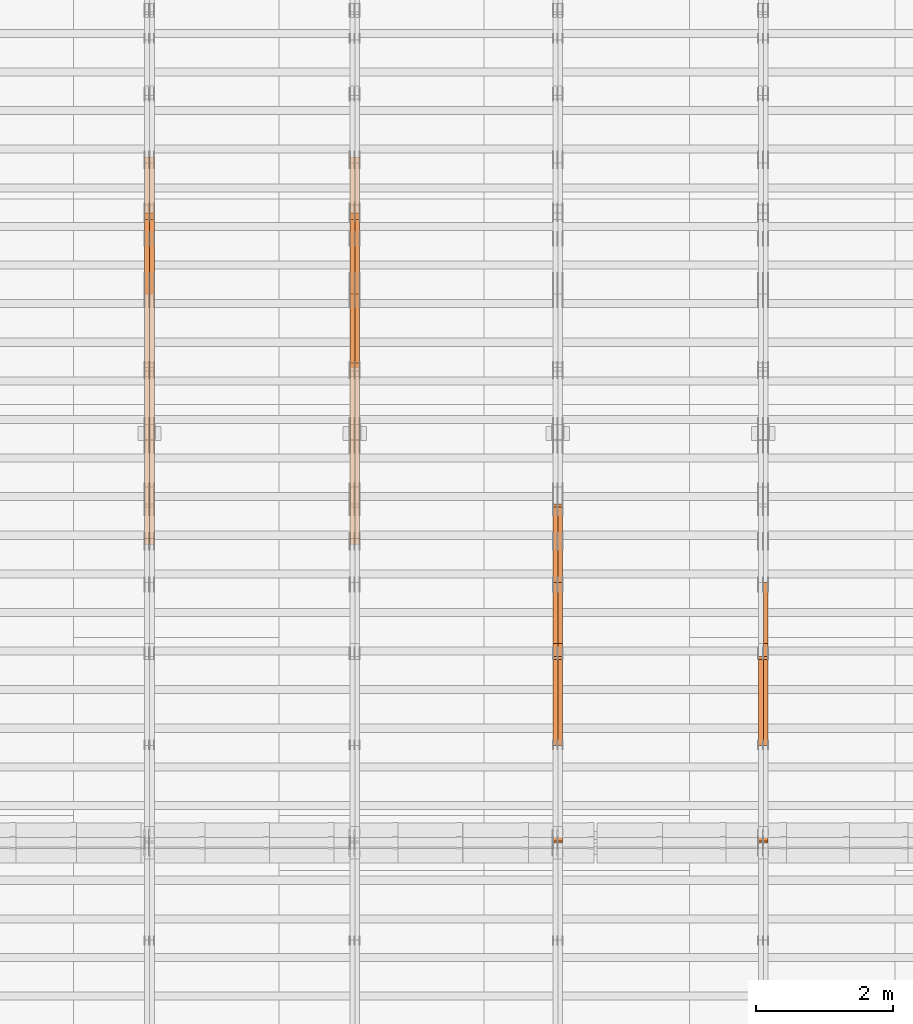
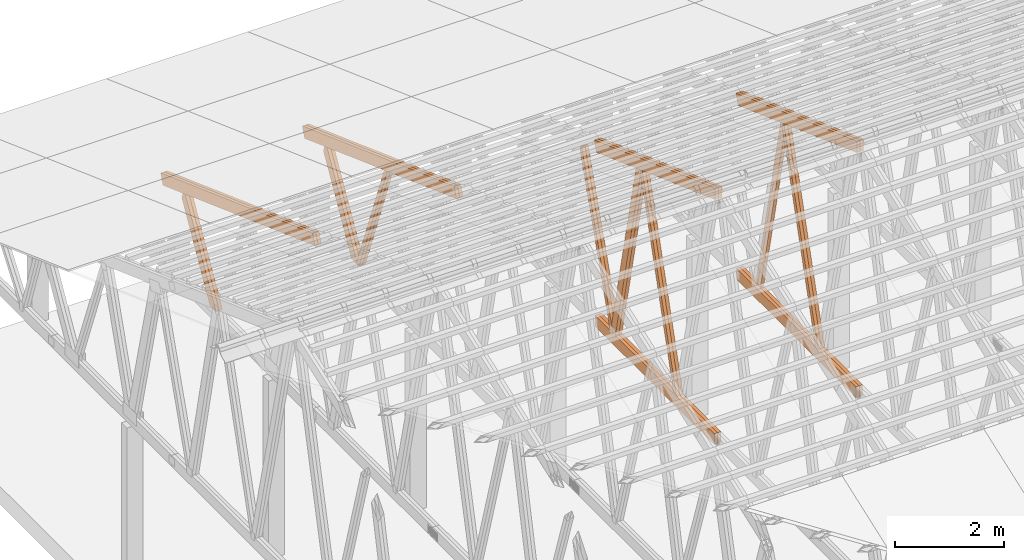
# One storey, part 33 of 189: 27 proxies.
"""IFC2X3 building model written with IfcOpenShell, lengths in millimetres."""

from ifc_helpers import new_model, entity, si_unit, converted_unit, derived_unit, direction, frame, origin, origin_2d_with_axis, place, context, subcontext, project, spatial, polyline, rectangle, outline, extrude, source, transform, mapped, material, type_object, type_shapes, element, save


model = new_model("IFC2X3")

# Units and contexts
model_context = context("Model", 3, precision=0.01, world=origin(), true_north=direction((6.12303176911189e-17, 1.0)))
body_context = subcontext(model_context, "Body", "Model", "MODEL_VIEW")
ifc_project = project(units=[si_unit("LENGTHUNIT", "METRE", prefix="MILLI"), si_unit("AREAUNIT", "SQUARE_METRE"), si_unit("VOLUMEUNIT", "CUBIC_METRE"), converted_unit("PLANEANGLEUNIT", "DEGREE", entity("IfcRatioMeasure", 0.0174532925199433), si_unit("PLANEANGLEUNIT", "RADIAN"), dimensions=[0, 0, 0, 0, 0, 0, 0]), si_unit("MASSUNIT", "GRAM", prefix="KILO"), derived_unit("MASSDENSITYUNIT", [(si_unit("MASSUNIT", "GRAM", prefix="KILO"), 1), (si_unit("LENGTHUNIT", "METRE"), -3)]), si_unit("TIMEUNIT", "SECOND"), si_unit("FREQUENCYUNIT", "HERTZ"), si_unit("THERMODYNAMICTEMPERATUREUNIT", "DEGREE_CELSIUS"), derived_unit("THERMALTRANSMITTANCEUNIT", [(si_unit("MASSUNIT", "GRAM", prefix="KILO"), 1), (si_unit("THERMODYNAMICTEMPERATUREUNIT", "KELVIN"), -1), (si_unit("TIMEUNIT", "SECOND"), -3)]), derived_unit("VOLUMETRICFLOWRATEUNIT", [(si_unit("LENGTHUNIT", "METRE"), 3), (si_unit("TIMEUNIT", "SECOND"), -1)]), si_unit("ELECTRICCURRENTUNIT", "AMPERE"), si_unit("ELECTRICVOLTAGEUNIT", "VOLT"), si_unit("POWERUNIT", "WATT"), si_unit("FORCEUNIT", "NEWTON"), si_unit("ILLUMINANCEUNIT", "LUX"), si_unit("LUMINOUSFLUXUNIT", "LUMEN"), si_unit("LUMINOUSINTENSITYUNIT", "CANDELA"), derived_unit("USERDEFINED", [(si_unit("MASSUNIT", "GRAM", prefix="KILO"), -1), (si_unit("LENGTHUNIT", "METRE"), -2), (si_unit("TIMEUNIT", "SECOND"), 3), (si_unit("LUMINOUSFLUXUNIT", "LUMEN"), 1)]), derived_unit("LINEARVELOCITYUNIT", [(si_unit("LENGTHUNIT", "METRE"), 1), (si_unit("TIMEUNIT", "SECOND"), -1)]), si_unit("PRESSUREUNIT", "PASCAL"), derived_unit("USERDEFINED", [(si_unit("LENGTHUNIT", "METRE"), -2), (si_unit("MASSUNIT", "GRAM", prefix="KILO"), 1), (si_unit("TIMEUNIT", "SECOND"), -2)])], contexts=[model_context])

# Site, building, storey
site_placement = place(None, origin())
site = spatial("IfcSite", under=ifc_project, at=site_placement, CompositionType="ELEMENT")
building_placement = place(site_placement, origin())
building = spatial("IfcBuilding", under=site, at=building_placement, CompositionType="ELEMENT")
storey_placement = place(building_placement, origin())
storey = spatial("IfcBuildingStorey", under=building, at=storey_placement, Name="Default", CompositionType="ELEMENT", Elevation=0.0)

# Proxies
ifc_material_1 = material(Name="IfcSurfaceStyle #68238")
building_element_proxy_type_1 = type_object("IfcBuildingElementProxyType", Name="T1-W6 68236", PredefinedType="NOTDEFINED", material=ifc_material_1)
shared_shape_1 = source(origin(), body_context, "Body", "SweptSolid", [
    extrude(outline(polyline([(-2668.68989660745, -47.5002238228721), (1800.72567700045, -47.5002238228721), (1797.68490303083, 0.000158637170537834), (1711.12272493628, 47.5001445042868), (-2640.84340836012, 47.5001445042868), (-2668.68989660745, -47.5002238228721)])), frame((1800.7257704503, 47.5001445042868, 0.0), z_axis=(0.0, 0.0, 1.0), x_axis=(-1.0, 0.0, 0.0)), (0.0, 0.0, 1.0), 69.9999999999997),
])
type_shapes(building_element_proxy_type_1, [shared_shape_1])
proxy_1_placement = place(building_placement, frame((12300.0, 17516.8749791841, 4507.23620831254), z_axis=(-1.0, 0.0, 0.0), x_axis=(0.0, -0.281285983104611, -0.959623986626466)))
element("IfcBuildingElementProxy", 1, at=proxy_1_placement, inside=storey, type_object=building_element_proxy_type_1, material=ifc_material_1, Name="T1-W6", context=body_context, shape_type="MappedRepresentation", body=[
    mapped(shared_shape_1, transform((0.0, 0.0, 0.0), scale=1.0)),
])
ifc_material_2 = material(Name="IfcSurfaceStyle #68172")
building_element_proxy_type_2 = type_object("IfcBuildingElementProxyType", Name="T1-W6 68170", PredefinedType="NOTDEFINED", material=ifc_material_2)
shared_shape_2 = source(origin(), body_context, "Body", "SweptSolid", [
    extrude(outline(polyline([(-2668.68989660745, -47.5002238228721), (1800.72567700045, -47.5002238228721), (1797.68490303083, 0.000158637170537834), (1711.12272493628, 47.5001445042868), (-2640.84340836012, 47.5001445042868), (-2668.68989660745, -47.5002238228721)])), frame((1800.7257704503, 47.5001445042868, 0.0), z_axis=(0.0, 0.0, 1.0), x_axis=(-1.0, 0.0, 0.0)), (0.0, 0.0, 1.0), 69.9999999999997),
])
type_shapes(building_element_proxy_type_2, [shared_shape_2])
proxy_2_placement = place(building_placement, frame((12230.0, 17516.8749791841, 4507.23620831254), z_axis=(-1.0, 0.0, 0.0), x_axis=(0.0, -0.281285983104611, -0.959623986626466)))
element("IfcBuildingElementProxy", 2, at=proxy_2_placement, inside=storey, type_object=building_element_proxy_type_2, material=ifc_material_2, Name="T1-W6", context=body_context, shape_type="MappedRepresentation", body=[
    mapped(shared_shape_2, transform((0.0, 0.0, 0.0), scale=1.0)),
])
ifc_material_3 = material(Name="IfcSurfaceStyle #67974")
building_element_proxy_type_3 = type_object("IfcBuildingElementProxyType", Name="T1-W3 67972", PredefinedType="NOTDEFINED", material=ifc_material_3)
shared_shape_3 = source(origin(), body_context, "Body", "SweptSolid", [
    extrude(outline(polyline([(-2517.58938959787, -85.0001104675026), (1625.445846867, -85.0001104675027), (1768.20563426494, 0.000209440697654673), (1749.48871563991, 85.0000057471538), (-2625.55080717397, 85.0000057471538), (-2517.58938959787, -85.0001104675026)])), frame((1768.2056683344, 85.0000547211315, 0.0), z_axis=(0.0, 0.0, 1.0), x_axis=(-1.0, 0.0, 0.0)), (0.0, 0.0, 1.0), 69.9999999999997),
])
type_shapes(building_element_proxy_type_3, [shared_shape_3])
proxy_3_placement = place(building_placement, frame((12300.0, 18415.3042863408, 226.720947016584), z_axis=(-1.0, 0.0, 0.0), x_axis=(0.0, -0.215047682154604, 0.976603550269982)))
element("IfcBuildingElementProxy", 3, at=proxy_3_placement, inside=storey, type_object=building_element_proxy_type_3, material=ifc_material_3, Name="T1-W3", context=body_context, shape_type="MappedRepresentation", body=[
    mapped(shared_shape_3, transform((0.0, 0.0, 0.0), scale=1.0)),
])
ifc_material_4 = material(Name="IfcSurfaceStyle #64464")
building_element_proxy_type_4 = type_object("IfcBuildingElementProxyType", Name="T1-B5 64462", PredefinedType="NOTDEFINED", material=ifc_material_4)
shared_shape_4 = source(origin(), body_context, "Body", "SweptSolid", [
    extrude(rectangle(XDim=4381.5, YDim=245.000000000001, at=origin_2d_with_axis()), frame((2190.75, 122.5, 0.0), z_axis=(0.0, 0.0, 1.0), x_axis=(-1.0, 0.0, 0.0)), (0.0, 0.0, 1.0), 69.9999999999997),
])
type_shapes(building_element_proxy_type_4, [shared_shape_4])
proxy_4_placement = place(building_placement, frame((12300.0, 14780.2587890625, 245.0), z_axis=(-1.0, 0.0, 0.0), x_axis=(0.0, 1.0, 0.0)))
element("IfcBuildingElementProxy", 4, at=proxy_4_placement, inside=storey, type_object=building_element_proxy_type_4, material=ifc_material_4, Name="T1-B5", context=body_context, shape_type="MappedRepresentation", body=[
    mapped(shared_shape_4, transform((0.0, 0.0, 0.0), scale=1.0)),
])
ifc_material_5 = material(Name="IfcSurfaceStyle #64407")
building_element_proxy_type_5 = type_object("IfcBuildingElementProxyType", Name="T1-B5 64405", PredefinedType="NOTDEFINED", material=ifc_material_5)
shared_shape_5 = source(origin(), body_context, "Body", "SweptSolid", [
    extrude(rectangle(XDim=4381.5, YDim=245.000000000001, at=origin_2d_with_axis()), frame((2190.75, 122.5, 0.0), z_axis=(0.0, 0.0, 1.0), x_axis=(-1.0, 0.0, 0.0)), (0.0, 0.0, 1.0), 69.9999999999997),
])
type_shapes(building_element_proxy_type_5, [shared_shape_5])
proxy_5_placement = place(building_placement, frame((12230.0, 14780.2587890625, 245.0), z_axis=(-1.0, 0.0, 0.0), x_axis=(0.0, 1.0, 0.0)))
element("IfcBuildingElementProxy", 5, at=proxy_5_placement, inside=storey, type_object=building_element_proxy_type_5, material=ifc_material_5, Name="T1-B5", context=body_context, shape_type="MappedRepresentation", body=[
    mapped(shared_shape_5, transform((0.0, 0.0, 0.0), scale=1.0)),
])
ifc_material_6 = material(Name="IfcSurfaceStyle #63648")
building_element_proxy_type_6 = type_object("IfcBuildingElementProxyType", Name="T1-T3 63646", PredefinedType="NOTDEFINED", material=ifc_material_6)
shared_shape_6 = source(origin(), body_context, "Body", "SweptSolid", [
    extrude(outline(polyline([(-2386.23525922045, -122.500022994835), (2341.64890001386, -122.500022994835), (2341.64888416412, 122.500022994835), (-2297.06252495753, 122.500022994835), (-2386.23525922045, -122.500022994835)])), frame((2341.64890001386, 122.500051926629, 0.0), z_axis=(0.0, 0.0, 1.0), x_axis=(-1.0, 0.0, 0.0)), (0.0, 0.0, 1.0), 69.9999999999997),
])
type_shapes(building_element_proxy_type_6, [shared_shape_6])
proxy_6_placement = place(building_placement, frame((12300.0, 19108.9628956236, 3921.30465489208), z_axis=(-1.0, 0.0, 0.0), x_axis=(0.0, -0.939692620785908, 0.342020143325669)))
element("IfcBuildingElementProxy", 6, at=proxy_6_placement, inside=storey, type_object=building_element_proxy_type_6, material=ifc_material_6, Name="T1-T3", context=body_context, shape_type="MappedRepresentation", body=[
    mapped(shared_shape_6, transform((0.0, 0.0, 0.0), scale=1.0)),
])
ifc_material_7 = material(Name="IfcSurfaceStyle #63591")
building_element_proxy_type_7 = type_object("IfcBuildingElementProxyType", Name="T1-T3 63589", PredefinedType="NOTDEFINED", material=ifc_material_7)
shared_shape_7 = source(origin(), body_context, "Body", "SweptSolid", [
    extrude(outline(polyline([(-2386.23525922045, -122.500022994835), (2341.64890001386, -122.500022994835), (2341.64888416412, 122.500022994835), (-2297.06252495753, 122.500022994835), (-2386.23525922045, -122.500022994835)])), frame((2341.64890001386, 122.500051926629, 0.0), z_axis=(0.0, 0.0, 1.0), x_axis=(-1.0, 0.0, 0.0)), (0.0, 0.0, 1.0), 69.9999999999997),
])
type_shapes(building_element_proxy_type_7, [shared_shape_7])
proxy_7_placement = place(building_placement, frame((12230.0, 19108.9628956236, 3921.30465489208), z_axis=(-1.0, 0.0, 0.0), x_axis=(0.0, -0.939692620785908, 0.342020143325669)))
element("IfcBuildingElementProxy", 7, at=proxy_7_placement, inside=storey, type_object=building_element_proxy_type_7, material=ifc_material_7, Name="T1-T3", context=body_context, shape_type="MappedRepresentation", body=[
    mapped(shared_shape_7, transform((0.0, 0.0, 0.0), scale=1.0)),
])
ifc_material_8 = material(Name="IfcSurfaceStyle #52448")
building_element_proxy_type_8 = type_object("IfcBuildingElementProxyType", Name="T1-W6 52446", PredefinedType="NOTDEFINED", material=ifc_material_8)
shared_shape_8 = source(origin(), body_context, "Body", "SweptSolid", [
    extrude(outline(polyline([(-2668.68989660745, -47.5002238228721), (1800.72567700045, -47.5002238228721), (1797.68490303083, 0.000158637170537834), (1711.12272493628, 47.5001445042868), (-2640.84340836012, 47.5001445042868), (-2668.68989660745, -47.5002238228721)])), frame((1800.7257704503, 47.5001445042868, 0.0), z_axis=(0.0, 0.0, 1.0), x_axis=(-1.0, 0.0, 0.0)), (0.0, 0.0, 1.0), 69.9999999999997),
])
type_shapes(building_element_proxy_type_8, [shared_shape_8])
proxy_8_placement = place(building_placement, frame((9300.0, 17516.8749791841, 4507.23620831254), z_axis=(-1.0, 0.0, 0.0), x_axis=(0.0, -0.281285983104611, -0.959623986626466)))
element("IfcBuildingElementProxy", 8, at=proxy_8_placement, inside=storey, type_object=building_element_proxy_type_8, material=ifc_material_8, Name="T1-W6", context=body_context, shape_type="MappedRepresentation", body=[
    mapped(shared_shape_8, transform((0.0, 0.0, 0.0), scale=1.0)),
])
ifc_material_9 = material(Name="IfcSurfaceStyle #52382")
building_element_proxy_type_9 = type_object("IfcBuildingElementProxyType", Name="T1-W6 52380", PredefinedType="NOTDEFINED", material=ifc_material_9)
shared_shape_9 = source(origin(), body_context, "Body", "SweptSolid", [
    extrude(outline(polyline([(-2668.68989660745, -47.5002238228721), (1800.72567700045, -47.5002238228721), (1797.68490303083, 0.000158637170537834), (1711.12272493628, 47.5001445042868), (-2640.84340836012, 47.5001445042868), (-2668.68989660745, -47.5002238228721)])), frame((1800.7257704503, 47.5001445042868, 0.0), z_axis=(0.0, 0.0, 1.0), x_axis=(-1.0, 0.0, 0.0)), (0.0, 0.0, 1.0), 69.9999999999997),
])
type_shapes(building_element_proxy_type_9, [shared_shape_9])
proxy_9_placement = place(building_placement, frame((9230.0, 17516.8749791841, 4507.23620831254), z_axis=(-1.0, 0.0, 0.0), x_axis=(0.0, -0.281285983104611, -0.959623986626466)))
element("IfcBuildingElementProxy", 9, at=proxy_9_placement, inside=storey, type_object=building_element_proxy_type_9, material=ifc_material_9, Name="T1-W6", context=body_context, shape_type="MappedRepresentation", body=[
    mapped(shared_shape_9, transform((0.0, 0.0, 0.0), scale=1.0)),
])
ifc_material_10 = material(Name="IfcSurfaceStyle #52184")
building_element_proxy_type_10 = type_object("IfcBuildingElementProxyType", Name="T1-W3 52182", PredefinedType="NOTDEFINED", material=ifc_material_10)
shared_shape_10 = source(origin(), body_context, "Body", "SweptSolid", [
    extrude(outline(polyline([(-2517.58938959787, -85.0001104675026), (1625.445846867, -85.0001104675027), (1768.20563426494, 0.000209440697654673), (1749.48871563991, 85.0000057471538), (-2625.55080717397, 85.0000057471538), (-2517.58938959787, -85.0001104675026)])), frame((1768.2056683344, 85.0000547211315, 0.0), z_axis=(0.0, 0.0, 1.0), x_axis=(-1.0, 0.0, 0.0)), (0.0, 0.0, 1.0), 69.9999999999997),
])
type_shapes(building_element_proxy_type_10, [shared_shape_10])
proxy_10_placement = place(building_placement, frame((9300.0, 18415.3042863408, 226.720947016584), z_axis=(-1.0, 0.0, 0.0), x_axis=(0.0, -0.215047682154604, 0.976603550269982)))
element("IfcBuildingElementProxy", 10, at=proxy_10_placement, inside=storey, type_object=building_element_proxy_type_10, material=ifc_material_10, Name="T1-W3", context=body_context, shape_type="MappedRepresentation", body=[
    mapped(shared_shape_10, transform((0.0, 0.0, 0.0), scale=1.0)),
])
ifc_material_11 = material(Name="IfcSurfaceStyle #52118")
building_element_proxy_type_11 = type_object("IfcBuildingElementProxyType", Name="T1-W3 52116", PredefinedType="NOTDEFINED", material=ifc_material_11)
shared_shape_11 = source(origin(), body_context, "Body", "SweptSolid", [
    extrude(outline(polyline([(-2517.58938959787, -85.0001104675026), (1625.445846867, -85.0001104675027), (1768.20563426494, 0.000209440697654673), (1749.48871563991, 85.0000057471538), (-2625.55080717397, 85.0000057471538), (-2517.58938959787, -85.0001104675026)])), frame((1768.2056683344, 85.0000547211315, 0.0), z_axis=(0.0, 0.0, 1.0), x_axis=(-1.0, 0.0, 0.0)), (0.0, 0.0, 1.0), 69.9999999999997),
])
type_shapes(building_element_proxy_type_11, [shared_shape_11])
proxy_11_placement = place(building_placement, frame((9230.0, 18415.3042863408, 226.720947016584), z_axis=(-1.0, 0.0, 0.0), x_axis=(0.0, -0.215047682154604, 0.976603550269982)))
element("IfcBuildingElementProxy", 11, at=proxy_11_placement, inside=storey, type_object=building_element_proxy_type_11, material=ifc_material_11, Name="T1-W3", context=body_context, shape_type="MappedRepresentation", body=[
    mapped(shared_shape_11, transform((0.0, 0.0, 0.0), scale=1.0)),
])
ifc_material_12 = material(Name="IfcSurfaceStyle #51920")
building_element_proxy_type_12 = type_object("IfcBuildingElementProxyType", Name="T1-W7 51918", PredefinedType="NOTDEFINED", material=ifc_material_12)
shared_shape_12 = source(origin(), body_context, "Body", "SweptSolid", [
    extrude(outline(polyline([(-2189.6662270939, -47.5000140805343), (1475.30081553583, -47.5000140805343), (1473.93388518462, 0.00042343352179337), (1398.58463533215, 47.4998023637734), (-2158.15310895869, 47.4998023637734), (-2189.6662270939, -47.5000140805343)])), frame((1475.30081553583, 47.5004895824757, 0.0), z_axis=(0.0, 0.0, 1.0), x_axis=(-1.0, 0.0, 0.0)), (0.0, 0.0, 1.0), 69.9999999999998),
])
type_shapes(building_element_proxy_type_12, [shared_shape_12])
proxy_12_placement = place(building_placement, frame((9300.0, 19742.3819153401, 3693.66743808885), z_axis=(-1.0, 0.0, 0.0), x_axis=(0.0, -0.314845237923104, -0.949143021971475)))
element("IfcBuildingElementProxy", 12, at=proxy_12_placement, inside=storey, type_object=building_element_proxy_type_12, material=ifc_material_12, Name="T1-W7", context=body_context, shape_type="MappedRepresentation", body=[
    mapped(shared_shape_12, transform((0.0, 0.0, 0.0), scale=1.0)),
])
ifc_material_13 = material(Name="IfcSurfaceStyle #51854")
building_element_proxy_type_13 = type_object("IfcBuildingElementProxyType", Name="T1-W7 51852", PredefinedType="NOTDEFINED", material=ifc_material_13)
shared_shape_13 = source(origin(), body_context, "Body", "SweptSolid", [
    extrude(outline(polyline([(-2189.6662270939, -47.5000140805343), (1475.30081553583, -47.5000140805343), (1473.93388518462, 0.00042343352179337), (1398.58463533215, 47.4998023637734), (-2158.15310895869, 47.4998023637734), (-2189.6662270939, -47.5000140805343)])), frame((1475.30081553583, 47.5004895824757, 0.0), z_axis=(0.0, 0.0, 1.0), x_axis=(-1.0, 0.0, 0.0)), (0.0, 0.0, 1.0), 69.9999999999998),
])
type_shapes(building_element_proxy_type_13, [shared_shape_13])
proxy_13_placement = place(building_placement, frame((9230.0, 19742.3819153401, 3693.66743808885), z_axis=(-1.0, 0.0, 0.0), x_axis=(0.0, -0.314845237923104, -0.949143021971475)))
element("IfcBuildingElementProxy", 13, at=proxy_13_placement, inside=storey, type_object=building_element_proxy_type_13, material=ifc_material_13, Name="T1-W7", context=body_context, shape_type="MappedRepresentation", body=[
    mapped(shared_shape_13, transform((0.0, 0.0, 0.0), scale=1.0)),
])
ifc_material_14 = material(Name="IfcSurfaceStyle #48674")
building_element_proxy_type_14 = type_object("IfcBuildingElementProxyType", Name="T1-B5 48672", PredefinedType="NOTDEFINED", material=ifc_material_14)
shared_shape_14 = source(origin(), body_context, "Body", "SweptSolid", [
    extrude(rectangle(XDim=4381.5, YDim=245.000000000001, at=origin_2d_with_axis()), frame((2190.75, 122.5, 0.0), z_axis=(0.0, 0.0, 1.0), x_axis=(-1.0, 0.0, 0.0)), (0.0, 0.0, 1.0), 69.9999999999997),
])
type_shapes(building_element_proxy_type_14, [shared_shape_14])
proxy_14_placement = place(building_placement, frame((9300.0, 14780.2587890625, 245.0), z_axis=(-1.0, 0.0, 0.0), x_axis=(0.0, 1.0, 0.0)))
element("IfcBuildingElementProxy", 14, at=proxy_14_placement, inside=storey, type_object=building_element_proxy_type_14, material=ifc_material_14, Name="T1-B5", context=body_context, shape_type="MappedRepresentation", body=[
    mapped(shared_shape_14, transform((0.0, 0.0, 0.0), scale=1.0)),
])
ifc_material_15 = material(Name="IfcSurfaceStyle #48617")
building_element_proxy_type_15 = type_object("IfcBuildingElementProxyType", Name="T1-B5 48615", PredefinedType="NOTDEFINED", material=ifc_material_15)
shared_shape_15 = source(origin(), body_context, "Body", "SweptSolid", [
    extrude(rectangle(XDim=4381.5, YDim=245.000000000001, at=origin_2d_with_axis()), frame((2190.75, 122.5, 0.0), z_axis=(0.0, 0.0, 1.0), x_axis=(-1.0, 0.0, 0.0)), (0.0, 0.0, 1.0), 69.9999999999997),
])
type_shapes(building_element_proxy_type_15, [shared_shape_15])
proxy_15_placement = place(building_placement, frame((9230.0, 14780.2587890625, 245.0), z_axis=(-1.0, 0.0, 0.0), x_axis=(0.0, 1.0, 0.0)))
element("IfcBuildingElementProxy", 15, at=proxy_15_placement, inside=storey, type_object=building_element_proxy_type_15, material=ifc_material_15, Name="T1-B5", context=body_context, shape_type="MappedRepresentation", body=[
    mapped(shared_shape_15, transform((0.0, 0.0, 0.0), scale=1.0)),
])
ifc_material_16 = material(Name="IfcSurfaceStyle #47858")
building_element_proxy_type_16 = type_object("IfcBuildingElementProxyType", Name="T1-T3 47856", PredefinedType="NOTDEFINED", material=ifc_material_16)
shared_shape_16 = source(origin(), body_context, "Body", "SweptSolid", [
    extrude(outline(polyline([(-2386.23525922045, -122.500022994835), (2341.64890001386, -122.500022994835), (2341.64888416412, 122.500022994835), (-2297.06252495753, 122.500022994835), (-2386.23525922045, -122.500022994835)])), frame((2341.64890001386, 122.500051926629, 0.0), z_axis=(0.0, 0.0, 1.0), x_axis=(-1.0, 0.0, 0.0)), (0.0, 0.0, 1.0), 69.9999999999997),
])
type_shapes(building_element_proxy_type_16, [shared_shape_16])
proxy_16_placement = place(building_placement, frame((9300.0, 19108.9628956236, 3921.30465489208), z_axis=(-1.0, 0.0, 0.0), x_axis=(0.0, -0.939692620785908, 0.342020143325669)))
element("IfcBuildingElementProxy", 16, at=proxy_16_placement, inside=storey, type_object=building_element_proxy_type_16, material=ifc_material_16, Name="T1-T3", context=body_context, shape_type="MappedRepresentation", body=[
    mapped(shared_shape_16, transform((0.0, 0.0, 0.0), scale=1.0)),
])
ifc_material_17 = material(Name="IfcSurfaceStyle #47801")
building_element_proxy_type_17 = type_object("IfcBuildingElementProxyType", Name="T1-T3 47799", PredefinedType="NOTDEFINED", material=ifc_material_17)
shared_shape_17 = source(origin(), body_context, "Body", "SweptSolid", [
    extrude(outline(polyline([(-2386.23525922045, -122.500022994835), (2341.64890001386, -122.500022994835), (2341.64888416412, 122.500022994835), (-2297.06252495753, 122.500022994835), (-2386.23525922045, -122.500022994835)])), frame((2341.64890001386, 122.500051926629, 0.0), z_axis=(0.0, 0.0, 1.0), x_axis=(-1.0, 0.0, 0.0)), (0.0, 0.0, 1.0), 69.9999999999997),
])
type_shapes(building_element_proxy_type_17, [shared_shape_17])
proxy_17_placement = place(building_placement, frame((9230.0, 19108.9628956236, 3921.30465489208), z_axis=(-1.0, 0.0, 0.0), x_axis=(0.0, -0.939692620785908, 0.342020143325669)))
element("IfcBuildingElementProxy", 17, at=proxy_17_placement, inside=storey, type_object=building_element_proxy_type_17, material=ifc_material_17, Name="T1-T3", context=body_context, shape_type="MappedRepresentation", body=[
    mapped(shared_shape_17, transform((0.0, 0.0, 0.0), scale=1.0)),
])
ifc_material_18 = material(Name="IfcSurfaceStyle #35338")
building_element_proxy_type_18 = type_object("IfcBuildingElementProxyType", Name="T1-W8 35336", PredefinedType="NOTDEFINED", material=ifc_material_18)
shared_shape_18 = source(origin(), body_context, "Body", "SweptSolid", [
    extrude(outline(polyline([(-1700.10906247918, -47.4998559987011), (1140.60243146647, -47.4998559987011), (1179.56122089033, 0.000120838919977206), (1161.65086478184, 47.4997955792411), (-1781.70545465947, 47.4997955792411), (-1700.10906247918, -47.4998559987011)])), frame((1179.56128464708, 47.5000634692093, 0.0), z_axis=(0.0, 0.0, 1.0), x_axis=(-1.0, 0.0, 0.0)), (0.0, 0.0, 1.0), 69.9999999999998),
])
type_shapes(building_element_proxy_type_18, [shared_shape_18])
proxy_18_placement = place(building_placement, frame((6335.0, 22687.5385403115, 228.241249073207), z_axis=(-1.0, 0.0, 0.0), x_axis=(0.0, -0.352814979177604, 0.93569310698963)))
element("IfcBuildingElementProxy", 18, at=proxy_18_placement, inside=storey, type_object=building_element_proxy_type_18, material=ifc_material_18, Name="T1-W8", context=body_context, shape_type="MappedRepresentation", body=[
    mapped(shared_shape_18, transform((0.0, 0.0, 0.0), scale=1.0)),
])
ifc_material_19 = material(Name="IfcSurfaceStyle #35272")
building_element_proxy_type_19 = type_object("IfcBuildingElementProxyType", Name="T1-W8 35270", PredefinedType="NOTDEFINED", material=ifc_material_19)
shared_shape_19 = source(origin(), body_context, "Body", "SweptSolid", [
    extrude(outline(polyline([(-1700.10906247918, -47.4998559987011), (1140.60243146647, -47.4998559987011), (1179.56122089033, 0.000120838919977206), (1161.65086478184, 47.4997955792411), (-1781.70545465947, 47.4997955792411), (-1700.10906247918, -47.4998559987011)])), frame((1179.56128464708, 47.5000634692093, 0.0), z_axis=(0.0, 0.0, 1.0), x_axis=(-1.0, 0.0, 0.0)), (0.0, 0.0, 1.0), 69.9999999999998),
])
type_shapes(building_element_proxy_type_19, [shared_shape_19])
proxy_19_placement = place(building_placement, frame((6265.0, 22687.5385403115, 228.241249073207), z_axis=(-1.0, 0.0, 0.0), x_axis=(0.0, -0.352814979177604, 0.93569310698963)))
element("IfcBuildingElementProxy", 19, at=proxy_19_placement, inside=storey, type_object=building_element_proxy_type_19, material=ifc_material_19, Name="T1-W8", context=body_context, shape_type="MappedRepresentation", body=[
    mapped(shared_shape_19, transform((0.0, 0.0, 0.0), scale=1.0)),
])
ifc_material_20 = material(Name="IfcSurfaceStyle #35074")
building_element_proxy_type_20 = type_object("IfcBuildingElementProxyType", Name="T1-W2 35072", PredefinedType="NOTDEFINED", material=ifc_material_20)
shared_shape_20 = source(origin(), body_context, "Body", "SweptSolid", [
    extrude(outline(polyline([(-1361.89144606429, -97.5000598486876), (887.613245225805, -97.5000598486876), (904.774262962339, 0.000302345139042259), (818.892339969004, 97.4999086761182), (-1249.38840209286, 97.4999086761182), (-1361.89144606429, -97.5000598486876)])), frame((904.774262962339, 97.5000966763391, 0.0), z_axis=(0.0, 0.0, 1.0), x_axis=(-1.0, 0.0, 0.0)), (0.0, 0.0, 1.0), 69.9999999999999),
])
type_shapes(building_element_proxy_type_20, [shared_shape_20])
proxy_20_placement = place(building_placement, frame((6335.0, 24033.6159173732, 2110.89189244614), z_axis=(-1.0, 0.0, 0.0), x_axis=(0.0, -0.5, -0.866025403784439)))
element("IfcBuildingElementProxy", 20, at=proxy_20_placement, inside=storey, type_object=building_element_proxy_type_20, material=ifc_material_20, Name="T1-W2", context=body_context, shape_type="MappedRepresentation", body=[
    mapped(shared_shape_20, transform((0.0, 0.0, 0.0), scale=1.0)),
])
ifc_material_21 = material(Name="IfcSurfaceStyle #35008")
building_element_proxy_type_21 = type_object("IfcBuildingElementProxyType", Name="T1-W2 35006", PredefinedType="NOTDEFINED", material=ifc_material_21)
shared_shape_21 = source(origin(), body_context, "Body", "SweptSolid", [
    extrude(outline(polyline([(-1361.89144606429, -97.5000598486876), (887.613245225805, -97.5000598486876), (904.774262962339, 0.000302345139042259), (818.892339969004, 97.4999086761182), (-1249.38840209286, 97.4999086761182), (-1361.89144606429, -97.5000598486876)])), frame((904.774262962339, 97.5000966763391, 0.0), z_axis=(0.0, 0.0, 1.0), x_axis=(-1.0, 0.0, 0.0)), (0.0, 0.0, 1.0), 69.9999999999999),
])
type_shapes(building_element_proxy_type_21, [shared_shape_21])
proxy_21_placement = place(building_placement, frame((6265.0, 24033.6159173732, 2110.89189244614), z_axis=(-1.0, 0.0, 0.0), x_axis=(0.0, -0.5, -0.866025403784439)))
element("IfcBuildingElementProxy", 21, at=proxy_21_placement, inside=storey, type_object=building_element_proxy_type_21, material=ifc_material_21, Name="T1-W2", context=body_context, shape_type="MappedRepresentation", body=[
    mapped(shared_shape_21, transform((0.0, 0.0, 0.0), scale=1.0)),
])
ifc_material_22 = material(Name="IfcSurfaceStyle #31954")
building_element_proxy_type_22 = type_object("IfcBuildingElementProxyType", Name="T1-T1 31952", PredefinedType="NOTDEFINED", material=ifc_material_22)
shared_shape_22 = source(origin(), body_context, "Body", "SweptSolid", [
    extrude(outline(polyline([(-2964.99982426074, -122.499947708046), (2964.99981923522, -122.499947708046), (2964.99984513599, 122.499947708046), (-2964.99984011047, 122.499947708046), (-2964.99982426074, -122.499947708046)])), frame((2964.99984513599, 122.499998966405, 0.0), z_axis=(0.0, 0.0, 1.0), x_axis=(-1.0, 0.0, 0.0)), (0.0, 0.0, 1.0), 69.9999999999996),
])
type_shapes(building_element_proxy_type_22, [shared_shape_22])
proxy_22_placement = place(building_placement, frame((6335.0, 24681.3398262186, 1893.12531804384), z_axis=(-1.0, 0.0, 0.0), x_axis=(0.0, -0.939692620785908, 0.342020143325669)))
element("IfcBuildingElementProxy", 22, at=proxy_22_placement, inside=storey, type_object=building_element_proxy_type_22, material=ifc_material_22, Name="T1-T1", context=body_context, shape_type="MappedRepresentation", body=[
    mapped(shared_shape_22, transform((0.0, 0.0, 0.0), scale=1.0)),
])
ifc_material_23 = material(Name="IfcSurfaceStyle #31897")
building_element_proxy_type_23 = type_object("IfcBuildingElementProxyType", Name="T1-T1 31895", PredefinedType="NOTDEFINED", material=ifc_material_23)
shared_shape_23 = source(origin(), body_context, "Body", "SweptSolid", [
    extrude(outline(polyline([(-2964.99982426074, -122.499947708046), (2964.99981923522, -122.499947708046), (2964.99984513599, 122.499947708046), (-2964.99984011047, 122.499947708046), (-2964.99982426074, -122.499947708046)])), frame((2964.99984513599, 122.499998966405, 0.0), z_axis=(0.0, 0.0, 1.0), x_axis=(-1.0, 0.0, 0.0)), (0.0, 0.0, 1.0), 69.9999999999996),
])
type_shapes(building_element_proxy_type_23, [shared_shape_23])
proxy_23_placement = place(building_placement, frame((6265.0, 24681.3398262186, 1893.12531804384), z_axis=(-1.0, 0.0, 0.0), x_axis=(0.0, -0.939692620785908, 0.342020143325669)))
element("IfcBuildingElementProxy", 23, at=proxy_23_placement, inside=storey, type_object=building_element_proxy_type_23, material=ifc_material_23, Name="T1-T1", context=body_context, shape_type="MappedRepresentation", body=[
    mapped(shared_shape_23, transform((0.0, 0.0, 0.0), scale=1.0)),
])
ifc_material_24 = material(Name="IfcSurfaceStyle #19284")
building_element_proxy_type_24 = type_object("IfcBuildingElementProxyType", Name="T1-W2 19282", PredefinedType="NOTDEFINED", material=ifc_material_24)
shared_shape_24 = source(origin(), body_context, "Body", "SweptSolid", [
    extrude(outline(polyline([(-1361.89144606429, -97.5000598486876), (887.613245225805, -97.5000598486876), (904.774262962339, 0.000302345139042259), (818.892339969004, 97.4999086761182), (-1249.38840209286, 97.4999086761182), (-1361.89144606429, -97.5000598486876)])), frame((904.774262962339, 97.5000966763391, 0.0), z_axis=(0.0, 0.0, 1.0), x_axis=(-1.0, 0.0, 0.0)), (0.0, 0.0, 1.0), 69.9999999999999),
])
type_shapes(building_element_proxy_type_24, [shared_shape_24])
proxy_24_placement = place(building_placement, frame((3335.0, 24033.6159173732, 2110.89189244614), z_axis=(-1.0, 0.0, 0.0), x_axis=(0.0, -0.5, -0.866025403784439)))
element("IfcBuildingElementProxy", 24, at=proxy_24_placement, inside=storey, type_object=building_element_proxy_type_24, material=ifc_material_24, Name="T1-W2", context=body_context, shape_type="MappedRepresentation", body=[
    mapped(shared_shape_24, transform((0.0, 0.0, 0.0), scale=1.0)),
])
ifc_material_25 = material(Name="IfcSurfaceStyle #19218")
building_element_proxy_type_25 = type_object("IfcBuildingElementProxyType", Name="T1-W2 19216", PredefinedType="NOTDEFINED", material=ifc_material_25)
shared_shape_25 = source(origin(), body_context, "Body", "SweptSolid", [
    extrude(outline(polyline([(-1361.89144606429, -97.5000598486876), (887.613245225805, -97.5000598486876), (904.774262962339, 0.000302345139042259), (818.892339969004, 97.4999086761182), (-1249.38840209286, 97.4999086761182), (-1361.89144606429, -97.5000598486876)])), frame((904.774262962339, 97.5000966763391, 0.0), z_axis=(0.0, 0.0, 1.0), x_axis=(-1.0, 0.0, 0.0)), (0.0, 0.0, 1.0), 69.9999999999999),
])
type_shapes(building_element_proxy_type_25, [shared_shape_25])
proxy_25_placement = place(building_placement, frame((3265.0, 24033.6159173732, 2110.89189244614), z_axis=(-1.0, 0.0, 0.0), x_axis=(0.0, -0.5, -0.866025403784439)))
element("IfcBuildingElementProxy", 25, at=proxy_25_placement, inside=storey, type_object=building_element_proxy_type_25, material=ifc_material_25, Name="T1-W2", context=body_context, shape_type="MappedRepresentation", body=[
    mapped(shared_shape_25, transform((0.0, 0.0, 0.0), scale=1.0)),
])
ifc_material_26 = material(Name="IfcSurfaceStyle #16164")
building_element_proxy_type_26 = type_object("IfcBuildingElementProxyType", Name="T1-T1 16162", PredefinedType="NOTDEFINED", material=ifc_material_26)
shared_shape_26 = source(origin(), body_context, "Body", "SweptSolid", [
    extrude(outline(polyline([(-2964.99982426074, -122.499947708046), (2964.99981923522, -122.499947708046), (2964.99984513599, 122.499947708046), (-2964.99984011047, 122.499947708046), (-2964.99982426074, -122.499947708046)])), frame((2964.99984513599, 122.499998966405, 0.0), z_axis=(0.0, 0.0, 1.0), x_axis=(-1.0, 0.0, 0.0)), (0.0, 0.0, 1.0), 69.9999999999996),
])
type_shapes(building_element_proxy_type_26, [shared_shape_26])
proxy_26_placement = place(building_placement, frame((3335.0, 24681.3398262186, 1893.12531804384), z_axis=(-1.0, 0.0, 0.0), x_axis=(0.0, -0.939692620785908, 0.342020143325669)))
element("IfcBuildingElementProxy", 26, at=proxy_26_placement, inside=storey, type_object=building_element_proxy_type_26, material=ifc_material_26, Name="T1-T1", context=body_context, shape_type="MappedRepresentation", body=[
    mapped(shared_shape_26, transform((0.0, 0.0, 0.0), scale=1.0)),
])
ifc_material_27 = material(Name="IfcSurfaceStyle #16107")
building_element_proxy_type_27 = type_object("IfcBuildingElementProxyType", Name="T1-T1 16105", PredefinedType="NOTDEFINED", material=ifc_material_27)
shared_shape_27 = source(origin(), body_context, "Body", "SweptSolid", [
    extrude(outline(polyline([(-2964.99982426074, -122.499947708046), (2964.99981923522, -122.499947708046), (2964.99984513599, 122.499947708046), (-2964.99984011047, 122.499947708046), (-2964.99982426074, -122.499947708046)])), frame((2964.99984513599, 122.499998966405, 0.0), z_axis=(0.0, 0.0, 1.0), x_axis=(-1.0, 0.0, 0.0)), (0.0, 0.0, 1.0), 69.9999999999996),
])
type_shapes(building_element_proxy_type_27, [shared_shape_27])
proxy_27_placement = place(building_placement, frame((3265.0, 24681.3398262186, 1893.12531804384), z_axis=(-1.0, 0.0, 0.0), x_axis=(0.0, -0.939692620785908, 0.342020143325669)))
element("IfcBuildingElementProxy", 27, at=proxy_27_placement, inside=storey, type_object=building_element_proxy_type_27, material=ifc_material_27, Name="T1-T1", context=body_context, shape_type="MappedRepresentation", body=[
    mapped(shared_shape_27, transform((0.0, 0.0, 0.0), scale=1.0)),
])

save(model, "model.ifc")
